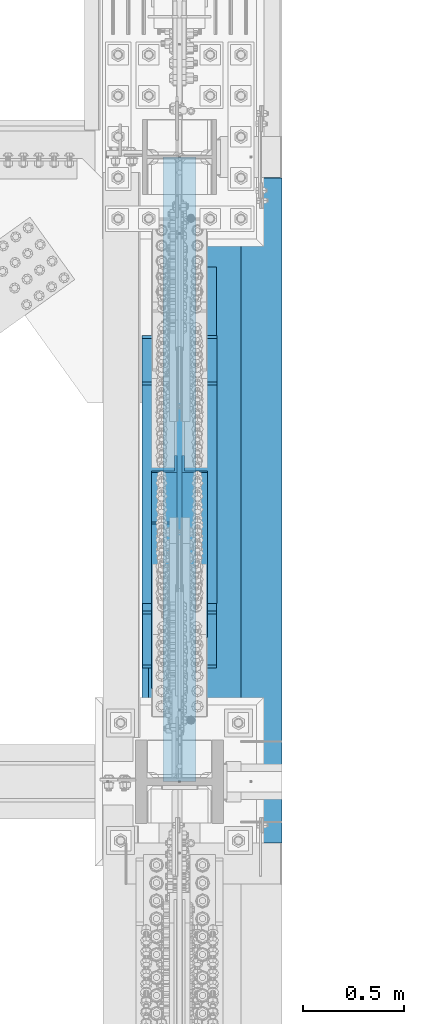
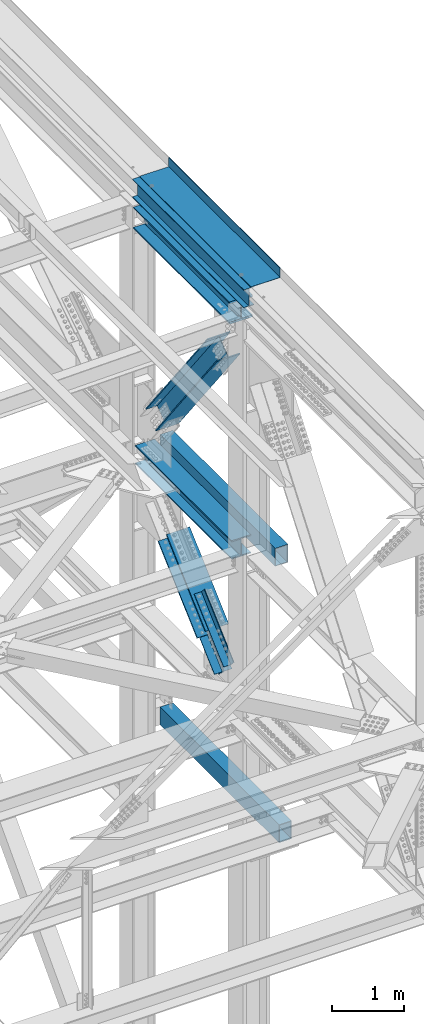
# One storey, part 1991 of 3843: 6 beams, 5 members, 7 elements without a shape of their own.
"""IFC2X3 building model written with IfcOpenShell, lengths in millimetres."""

import ifcopenshell
import ifcopenshell.guid

model = None  # the IFC model being written
_history = None  # IfcOwnerHistory: only IFC2X3 demands one
_inside = {}  # id of a spatial element -> (the spatial element, [elements in it])
_under = {}  # id of a project, library or spatial element -> (it, [spatial elements below it])
_declared = {}  # id of a project -> (the project, [libraries it declares])
_typed = {}  # id of a type object -> (the type object, [elements of that type])
_made_of = {}  # id of a material, layer set ... -> (it, [elements and type objects made of it])


def new_model(schema):
    """Start an empty IFC model of exactly this schema.

    Asked for "IFC4X3", IfcOpenShell would pick the latest addendum, in which some entities
    have other attributes; the version numbers below select the first issue.
    IFC2X3 requires an IfcOwnerHistory on every rooted entity: one is made here for all.
    """
    global model, _history
    if schema == "IFC4X3":
        model = ifcopenshell.file(schema_version=(4, 3, 0, 0))
    else:
        model = ifcopenshell.file(schema=schema)
    _inside.clear()
    _under.clear()
    _declared.clear()
    _typed.clear()
    _made_of.clear()
    _history = None
    if model.schema == "IFC2X3":
        org = make("IfcOrganization", Name="unknown")
        user = make(
            "IfcPersonAndOrganization",
            ThePerson=make("IfcPerson", FamilyName="unknown"),
            TheOrganization=org,
        )
        app = make(
            "IfcApplication",
            ApplicationDeveloper=org,
            Version="unknown",
            ApplicationFullName="unknown",
            ApplicationIdentifier="unknown",
        )
        _history = make(
            "IfcOwnerHistory",
            OwningUser=user,
            OwningApplication=app,
            ChangeAction="ADDED",
            CreationDate=0,
        )
    return model


def make(cls, **values):
    """One entity of the class cls with the attributes given. An attribute that is None is left unset."""
    return model.create_entity(
        cls, **{name: value for name, value in values.items() if value is not None}
    )


def rooted(cls, **values):
    """An entity with a GlobalId (a new one), such as an element, a storey or a relation."""
    return make(cls, GlobalId=ifcopenshell.guid.new(), OwnerHistory=_history, **values)


def si_unit(unit_type, name, prefix=None):
    """IfcSIUnit, for example si_unit("LENGTHUNIT", "METRE", prefix="MILLI")."""
    return make("IfcSIUnit", UnitType=unit_type, Prefix=prefix, Name=name)


def assignment(units):
    """IfcUnitAssignment: the units of a project."""
    return None if units is None else make("IfcUnitAssignment", Units=units)


def point(xyz):
    """IfcCartesianPoint."""
    return None if xyz is None else make("IfcCartesianPoint", Coordinates=xyz)


def direction(xyz):
    """IfcDirection."""
    return None if xyz is None else make("IfcDirection", DirectionRatios=xyz)


def frame(location, z_axis=None, x_axis=None):
    """IfcAxis2Placement3D, a coordinate frame: its origin and axes. An axis left out is left unset."""
    return make(
        "IfcAxis2Placement3D",
        Location=point(location),
        Axis=direction(z_axis),
        RefDirection=direction(x_axis),
    )


def origin_with_axes():
    """The frame at (0, 0, 0) with the z axis (0, 0, 1) and the x axis (1, 0, 0) written out."""
    return frame((0.0, 0.0, 0.0), z_axis=(0.0, 0.0, 1.0), x_axis=(1.0, 0.0, 0.0))


def place(relative_to, where):
    """IfcLocalPlacement: puts the frame where relative to a parent placement (None: the world)."""
    return make(
        "IfcLocalPlacement", PlacementRelTo=relative_to, RelativePlacement=where
    )


def context(
    kind, dimensions, precision=None, world=None, true_north=None, identifier=None
):
    """IfcGeometricRepresentationContext, for example the 3D "Model" context."""
    return make(
        "IfcGeometricRepresentationContext",
        ContextIdentifier=identifier,
        ContextType=kind,
        CoordinateSpaceDimension=dimensions,
        Precision=precision,
        WorldCoordinateSystem=world,
        TrueNorth=true_north,
    )


def subcontext(parent, identifier, kind, view, scale=None):
    """IfcGeometricRepresentationSubContext, for example "Body" below "Model"."""
    return make(
        "IfcGeometricRepresentationSubContext",
        ContextIdentifier=identifier,
        ContextType=kind,
        ParentContext=parent,
        TargetScale=scale,
        TargetView=view,
    )


def project(units=None, contexts=None):
    """IfcProject with its units and contexts."""
    return rooted(
        "IfcProject",
        Name="project",
        RepresentationContexts=contexts,
        UnitsInContext=assignment(units),
    )


def spatial(cls, under=None, at=None, **own):
    """A site, building, storey or space (cls), placed at a placement, below another one or the project."""
    s = rooted(cls, ObjectPlacement=at, **own)
    if under is not None:
        _under.setdefault(under.id(), (under, []))[1].append(s)
    return s


def faces_of(points, faces, orient=None, outer=None):
    """IfcFace entities. A face is a list of loops; a loop is a list of indices into points, from 0.

    orient and outer hold one flag for each loop. By default every Orientation is true, the
    first loop of a face is its IfcFaceOuterBound and the others are IfcFaceBound.
    """
    made = []
    for i, loops in enumerate(faces):
        bounds = []
        for j, loop in enumerate(loops):
            is_outer = j == 0 if outer is None else outer[i][j]
            bounds.append(
                make(
                    "IfcFaceOuterBound" if is_outer else "IfcFaceBound",
                    Bound=make("IfcPolyLoop", Polygon=[points[k] for k in loop]),
                    Orientation=True if orient is None else orient[i][j],
                )
            )
        made.append(make("IfcFace", Bounds=bounds))
    return made


def faceted_brep(points, faces, orient=None, outer=None, voids=None):
    """IfcFacetedBrep: a solid bounded by flat faces; with voids (closed shells), ...WithVoids."""
    shared = [point(p) for p in points]
    hull = make("IfcClosedShell", CfsFaces=faces_of(shared, faces, orient, outer))
    if voids is None:
        return make("IfcFacetedBrep", Outer=hull)
    return make(
        "IfcFacetedBrepWithVoids",
        Outer=hull,
        Voids=[
            make(cls, CfsFaces=faces_of(shared, fs, o, b)) for cls, fs, o, b in voids
        ],
    )


def shape(context_of_items, identifier, shape_type, items):
    """IfcShapeRepresentation: the items that make up one representation, for example the "Body"."""
    return make(
        "IfcShapeRepresentation",
        ContextOfItems=context_of_items,
        RepresentationIdentifier=identifier,
        RepresentationType=shape_type,
        Items=items,
    )


def material(Name=None, Category=None):
    """IfcMaterial."""
    return make("IfcMaterial", Name=Name, Category=Category)


def made_of(thing, what):
    """Note that an element or type object is made of a material, layer set ...; save() writes the relation."""
    if what is not None:
        _made_of.setdefault(what.id(), (what, []))[1].append(thing)
    return thing


def type_object(cls, material=None, **own):
    """A type object (cls), such as IfcWallType, which elements share."""
    return made_of(rooted(cls, **own), material)


def element(
    cls,
    number,
    at=None,
    inside=None,
    cuts=None,
    type_object=None,
    material=None,
    context=None,
    identifier="Body",
    shape_type=None,
    held_by="IfcProductDefinitionShape",
    body=None,
    shapes=None,
    **own,
):
    """One element of the class cls, such as IfcWall. Its Tag is "e" and its number.

    at: its placement. inside: the storey or other place that contains it. cuts: it is an
    opening in that element (IfcRelVoidsElement). A single representation is given by context,
    identifier, shape_type and body (its items); several are given by shapes. held_by: the class
    of the entity that holds the representations. save() writes the other relations.
    """
    e = rooted(cls, Tag="e%d" % number, ObjectPlacement=at, **own)
    if body is not None:
        shapes = [shape(context, identifier, shape_type, body)]
    if shapes is not None:
        e.Representation = make(held_by, Representations=shapes)
    if inside is not None:
        _inside.setdefault(inside.id(), (inside, []))[1].append(e)
    if cuts is not None:
        rooted(
            "IfcRelVoidsElement", RelatingBuildingElement=cuts, RelatedOpeningElement=e
        )
    if type_object is not None:
        _typed.setdefault(type_object.id(), (type_object, []))[1].append(e)
    return made_of(e, material)


def aggregate(whole, parts):
    """IfcRelAggregates: a whole, such as a stair, and the parts it consists of."""
    return rooted("IfcRelAggregates", RelatingObject=whole, RelatedObjects=parts)


def save(model, path):
    """Write the relations noted so far, then the file.

    IfcRelAggregates (storeys below a building ...), IfcRelContainedInSpatialStructure (elements
    in a storey), IfcRelDefinesByType, IfcRelAssociatesMaterial and IfcRelDeclares: one each for
    every whole, place, type object, material and project.
    """
    for whole, parts in _under.values():
        aggregate(whole, parts)
    for where, things in _inside.values():
        rooted(
            "IfcRelContainedInSpatialStructure",
            RelatedElements=things,
            RelatingStructure=where,
        )
    for kind, things in _typed.values():
        rooted("IfcRelDefinesByType", RelatedObjects=things, RelatingType=kind)
    for what, things in _made_of.values():
        rooted("IfcRelAssociatesMaterial", RelatedObjects=things, RelatingMaterial=what)
    for by, libraries in _declared.values():
        rooted("IfcRelDeclares", RelatingContext=by, RelatedDefinitions=libraries)
    model.write(path)


model = new_model("IFC2X3")

# Units and contexts
model_context = context("Model", 3, precision=1e-05, world=origin_with_axes())
body_context = subcontext(model_context, "Body", "Model", "MODEL_VIEW")
ifc_project = project(units=[si_unit("LENGTHUNIT", "METRE", prefix="MILLI"), si_unit("AREAUNIT", "SQUARE_METRE"), si_unit("VOLUMEUNIT", "CUBIC_METRE"), si_unit("MASSUNIT", "GRAM", prefix="KILO"), si_unit("TIMEUNIT", "SECOND"), si_unit("PLANEANGLEUNIT", "RADIAN"), si_unit("SOLIDANGLEUNIT", "STERADIAN"), si_unit("THERMODYNAMICTEMPERATUREUNIT", "DEGREE_CELSIUS"), si_unit("LUMINOUSINTENSITYUNIT", "LUMEN")], contexts=[model_context])

# Site, building, storey
site_placement = place(None, origin_with_axes())
site = spatial("IfcSite", under=ifc_project, at=site_placement, CompositionType="ELEMENT")
building_placement = place(site_placement, origin_with_axes())
building = spatial("IfcBuilding", under=site, at=building_placement, Name="Undefined", CompositionType="ELEMENT")
storey_placement = place(building_placement, origin_with_axes())
storey = spatial("IfcBuildingStorey", under=building, at=storey_placement, Name="Undefined", CompositionType="ELEMENT", Elevation=0.0)

# Assembly, beam
assembly_1_placement = place(storey_placement, origin_with_axes())
assembly_1 = element("IfcElementAssembly", 1, at=assembly_1_placement, inside=storey, Name="BEAM", AssemblyPlace="NOTDEFINED", PredefinedType="RIGID_FRAME")
ifc_material_1 = material(Name="STEEL/A992")
beam_type_1 = type_object("IfcBeamType", Name="W12X26", PredefinedType="NOTDEFINED")
beam_1_placement = place(assembly_1_placement, frame((85648.8000000031, 89115.9, 46612.1750000001), z_axis=(0.0, 0.0, 1.0), x_axis=(0.0, 1.0, 0.0)))
beam_1 = element("IfcBeam", 2, at=beam_1_placement, type_object=beam_type_1, material=ifc_material_1, Name="BEAM", ObjectType="W12X26", context=body_context, shape_type="Brep", body=[
    faceted_brep([(0.0, 82.5500000000029, -155.574999999997), (0.0, 82.5500000000029, -146.050000000003), (3098.79999999999, 82.5500000000029, -146.050000000003), (3098.79999999999, 82.5500000000029, -155.574999999997), (0.0, 3.17500000000291, -146.050000000003), (3098.79999999999, 3.17500000000291, -146.050000000003), (0.0, 3.17500000000291, 146.050000000003), (3098.79999999999, 3.17500000000291, 146.050000000003), (0.0, 82.5500000000029, 146.050000000003), (3098.79999999999, 82.5500000000029, 146.050000000003), (0.0, 82.5500000000029, 155.574999999997), (3098.79999999999, 82.5500000000029, 155.574999999997), (0.0, -82.5500000000029, 155.574999999997), (3098.79999999999, -82.5500000000029, 155.574999999997), (0.0, -82.5500000000029, 146.050000000003), (3098.79999999999, -82.5500000000029, 146.050000000003), (0.0, -3.17500000000291, 146.050000000003), (3098.79999999999, -3.17500000000291, 146.050000000003), (0.0, -3.17500000000291, -146.050000000003), (3098.79999999999, -3.17500000000291, -146.050000000003), (0.0, -82.5500000000029, -146.050000000003), (3098.79999999999, -82.5500000000029, -146.050000000003), (0.0, -82.5500000000029, -155.574999999997), (3098.79999999999, -82.5500000000029, -155.574999999997)], [[[0, 1, 2, 3]], [[1, 4, 5, 2]], [[4, 6, 7, 5]], [[6, 8, 9, 7]], [[8, 10, 11, 9]], [[10, 12, 13, 11]], [[12, 14, 15, 13]], [[14, 16, 17, 15]], [[16, 18, 19, 17]], [[18, 20, 21, 19]], [[20, 22, 23, 21]], [[22, 0, 3, 23]], [[5, 7, 9, 11, 13, 15, 17, 19, 21, 23, 3, 2]], [[22, 20, 18, 16, 14, 12, 10, 8, 6, 4, 1, 0]]]),
])

assembly_2_placement = place(storey_placement, origin_with_axes())
assembly_2 = element("IfcElementAssembly", 3, at=assembly_2_placement, inside=storey, Name="GIRT", AssemblyPlace="NOTDEFINED", PredefinedType="RIGID_FRAME")
ifc_material_2 = material()
beam_type_2 = type_object("IfcBeamType", Name="HSS12X8X3/8", PredefinedType="NOTDEFINED")
beam_2_placement = place(assembly_2_placement, frame((86055.2, 88912.7, 42214.8), z_axis=(0.0, 0.0, 1.0), x_axis=(0.0, 1.0, 0.0)))
beam_2 = element("IfcBeam", 4, at=beam_2_placement, type_object=beam_type_2, material=ifc_material_2, Name="GIRT", ObjectType="HSS12X8X3/8", context=body_context, shape_type="Brep", body=[
    faceted_brep([(6.35000000002037, -101.600000000006, -152.400000000001), (6.35000000002037, 101.600000000006, -152.400000000001), (3198.81250000004, 101.600000000006, -152.400000000001), (3198.81250000004, -101.600000000006, -152.400000000001), (6.35000000002037, -101.600000000006, 152.400000000001), (3198.81250000004, -101.600000000006, 152.400000000001), (6.35000000002037, 101.600000000006, 152.400000000001), (3198.81250000004, 101.600000000006, 152.400000000001), (6.35000000002037, 92.0749999999971, 142.875), (6.35000000002037, -92.0749999999971, 142.875), (6.35000000002037, -92.0749999999971, -142.875), (6.35000000002037, 92.0749999999971, -142.875), (3198.81250000004, -92.0749999999971, 142.875), (3198.81250000004, -92.0749999999971, -142.875), (3198.81250000004, 92.0749999999971, -142.875), (3198.81250000004, 92.0749999999971, 142.875)], [[[0, 1, 2, 3]], [[4, 0, 3, 5]], [[6, 4, 5, 7]], [[1, 6, 7, 2]], [[0, 4, 6, 1], [8, 9, 10, 11]], [[10, 9, 12, 13]], [[11, 10, 13, 14]], [[8, 11, 14, 15]], [[9, 8, 15, 12]], [[2, 7, 5, 3], [14, 13, 12, 15]]]),
])
aggregate(assembly_2, [beam_2])

assembly_3_placement = place(storey_placement, origin_with_axes())
assembly_3 = element("IfcElementAssembly", 5, at=assembly_3_placement, inside=storey, Name="GIRT", AssemblyPlace="NOTDEFINED", PredefinedType="RIGID_FRAME")
beam_3_placement = place(assembly_3_placement, frame((86055.2, 88812.6870000123, 37592.0), z_axis=(0.0, 0.0, 1.0), x_axis=(0.0, 1.0, 0.0)))
beam_3 = element("IfcBeam", 6, at=beam_3_placement, type_object=beam_type_2, material=ifc_material_2, Name="GIRT", ObjectType="HSS12X8X3/8", context=body_context, shape_type="Brep", body=[
    faceted_brep([(0.0, 92.0749999999971, -142.875), (0.0, -92.0749999999971, -142.875), (3298.82599997523, -92.0749999999971, -142.875), (3298.82599997523, 92.0749999999971, -142.875), (0.0, -92.0749999999971, 142.875), (3298.82599997523, -92.0749999999971, 142.875), (0.0, 92.0749999999971, 142.875), (3298.82599997523, 92.0749999999971, 142.875), (0.0, 101.600000000006, -152.400000000001), (0.0, 101.600000000006, 152.400000000001), (3298.82599997523, 101.600000000006, 152.400000000001), (3298.82599997523, 101.600000000006, -152.400000000001), (0.0, -101.600000000006, 152.400000000001), (3298.82599997523, -101.600000000006, 152.400000000001), (0.0, -101.600000000006, -152.400000000001), (3298.82599997523, -101.600000000006, -152.400000000001)], [[[0, 1, 2, 3]], [[1, 4, 5, 2]], [[4, 6, 7, 5]], [[6, 0, 3, 7]], [[8, 9, 10, 11]], [[9, 12, 13, 10]], [[12, 14, 15, 13]], [[14, 8, 11, 15]], [[13, 15, 11, 10], [5, 7, 3, 2]], [[14, 12, 9, 8], [6, 4, 1, 0]]]),
])
aggregate(assembly_3, [beam_3])

assembly_4_placement = place(storey_placement, origin_with_axes())
assembly_4 = element("IfcElementAssembly", 7, at=assembly_4_placement, inside=storey, Name="BEAM", AssemblyPlace="NOTDEFINED", PredefinedType="RIGID_FRAME")
beam_type_3 = type_object("IfcBeamType", Name="W14X120", PredefinedType="NOTDEFINED")
beam_4_placement = place(assembly_4_placement, frame((85648.7999996898, 89115.9000000775, 46272.45), z_axis=(0.0, 0.0, 1.0), x_axis=(0.0, 1.0, 0.0)))
beam_4 = element("IfcBeam", 8, at=beam_4_placement, type_object=beam_type_3, material=ifc_material_1, Name="BEAM", ObjectType="W14X120", context=body_context, shape_type="Brep", body=[
    faceted_brep([(229.648571506506, -185.737500000003, 184.150000000001), (229.648571506506, 185.737500000003, 184.150000000001), (215.89999999998, 185.737500000003, 160.337500000001), (215.89999999998, 7.14375000000291, 160.337500000001), (215.89999999998, -7.14375000000291, 160.337500000001), (215.89999999998, -185.737500000003, 160.337500000001), (2903.53749999998, -185.737500000003, -184.150000000001), (2889.78891587461, -185.737500000003, -160.337500000001), (229.648584125331, -185.737500000003, -160.337500000001), (215.89999999998, -185.737500000003, -184.150000000001), (2903.53749999998, 185.737500000003, -184.150000000001), (215.89999999998, 185.737500000003, -184.150000000001), (2889.78891587461, 185.737500000003, -160.337500000001), (229.648584125331, 185.737500000003, -160.337500000001), (2889.78891587461, 7.14375000000291, -160.337500000001), (229.648584125331, 7.14375000000291, -160.337500000001), (2889.55970728036, 7.14375000000291, -159.940499496464), (2889.55970728036, -7.14375000000291, -159.940499496464), (2889.78891587461, -7.14375000000291, -160.337500000001), (2882.98050683591, 7.14375000000291, -159.940499496464), (2882.98050683591, -7.14375000000291, -159.940499496464), (2829.67387659333, 7.14375000000291, -150.671698168706), (2829.67387659333, -7.14375000000291, -150.671698168706), (2824.70199420204, 7.14375000000291, -148.151780799373), (2824.70199420204, -7.14375000000291, -148.151780799373), (2821.99155201387, 7.14375000000291, -143.281144166889), (2821.99155201387, -7.14375000000291, -143.281144166889), (2822.47075918806, 7.14375000000291, -137.72777054851), (2822.47075918806, -7.14375000000291, -137.72777054851), (2825.97550800437, 7.14375000000291, -133.39345009478), (2825.97550800437, -7.14375000000291, -133.39345009478), (2831.30557365589, 7.14375000000291, -131.762500000004), (2831.30557365589, -7.14375000000291, -131.762500000004), (2900.36249999997, 7.14375000000291, -131.762500000004), (2900.36249999997, -7.14375000000291, -131.762500000004), (2900.36249999997, -7.14375000000291, 131.762500000004), (2900.36249999997, 7.14375000000291, 131.762500000004), (2826.46256780367, 7.14375000000291, 131.762500000004), (2826.46256780367, -7.14375000000291, 131.762500000004), (2821.13250216469, 7.14375000000291, 133.393450086303), (2821.13250216469, -7.14375000000291, 133.393450086303), (2817.62775334714, 7.14375000000291, 137.727770520425), (2817.62775334714, -7.14375000000291, 137.727770520425), (2817.14854615215, 7.14375000000291, 143.281144122484), (2817.14854615215, -7.14375000000291, 143.281144122484), (2819.85898830618, 7.14375000000291, 148.151780757398), (2819.85898830618, -7.14375000000291, 148.151780757398), (2824.83087066654, 7.14375000000291, 150.67169815574), (2824.83087066654, -7.14375000000291, 150.67169815574), (2878.1374984741, 7.14375000000291, 159.940499496464), (2878.1374984741, -7.14375000000291, 159.940499496464), (2903.53749999998, 7.14375000000291, 159.940499496464), (2903.53749999998, -7.14375000000291, 159.940499496464), (2903.53749999998, 7.14375000000291, 160.337500000001), (2903.53749999998, -7.14375000000291, 160.337500000001), (2903.53749999998, -185.737500000003, 160.337500000001), (2903.53749999998, 185.737500000003, 160.337500000001), (2889.78892849344, 185.737500000003, 184.150000000001), (2889.78892849344, -185.737500000003, 184.150000000001), (215.89999999998, 7.14375000000291, 159.940499496464), (215.89999999998, -7.14375000000291, 159.940499496464), (241.300001525844, 7.14375000000291, 159.940499496464), (241.300001525844, -7.14375000000291, 159.940499496464), (294.606629333401, 7.14375000000291, 150.67169815574), (294.606629333401, -7.14375000000291, 150.67169815574), (299.578511693762, 7.14375000000291, 148.151780757398), (299.578511693762, -7.14375000000291, 148.151780757398), (302.28895384779, 7.14375000000291, 143.281144122484), (302.28895384779, -7.14375000000291, 143.281144122484), (301.809746652798, 7.14375000000291, 137.727770520425), (301.809746652798, -7.14375000000291, 137.727770520425), (298.30499783525, 7.14375000000291, 133.393450086303), (298.30499783525, -7.14375000000291, 133.393450086303), (292.974932196274, 7.14375000000291, 131.762500000004), (292.974932196274, -7.14375000000291, 131.762500000004), (219.074999999968, 7.14375000000291, 131.762500000004), (219.074999999968, -7.14375000000291, 131.762500000004), (219.074999999968, 7.14375000000291, -131.762500000004), (219.074999999968, -7.14375000000291, -131.762500000004), (288.131926344053, 7.14375000000291, -131.762500000004), (288.131926344053, -7.14375000000291, -131.762500000004), (293.461991995573, 7.14375000000291, -133.39345009478), (293.461991995573, -7.14375000000291, -133.39345009478), (296.966740811884, 7.14375000000291, -137.72777054851), (296.966740811884, -7.14375000000291, -137.72777054851), (297.445947986067, 7.14375000000291, -143.281144166889), (297.445947986067, -7.14375000000291, -143.281144166889), (294.7355057979, 7.14375000000291, -148.151780799373), (294.7355057979, -7.14375000000291, -148.151780799373), (289.763623406616, 7.14375000000291, -150.671698168706), (289.763623406616, -7.14375000000291, -150.671698168706), (236.456993164029, 7.14375000000291, -159.940499496464), (236.456993164029, -7.14375000000291, -159.940499496464), (229.877792719577, 7.14375000000291, -159.940499496464), (229.877792719577, -7.14375000000291, -159.940499496464), (229.648584125331, -7.14375000000291, -160.337500000001)], [[[0, 1, 2, 3, 4, 5]], [[6, 7, 8, 9]], [[10, 6, 9, 11]], [[12, 10, 11, 13]], [[14, 12, 13, 15]], [[6, 10, 12, 14, 16, 17, 18, 7]], [[19, 20, 17, 16]], [[20, 19, 21, 22]], [[22, 21, 23, 24]], [[24, 23, 25, 26]], [[26, 25, 27, 28]], [[28, 27, 29, 30]], [[30, 29, 31, 32]], [[32, 31, 33, 34]], [[35, 34, 33, 36]], [[37, 38, 35, 36]], [[38, 37, 39, 40]], [[40, 39, 41, 42]], [[42, 41, 43, 44]], [[44, 43, 45, 46]], [[46, 45, 47, 48]], [[48, 47, 49, 50]], [[50, 49, 51, 52]], [[52, 51, 53, 54]], [[55, 54, 53, 56, 57, 58]], [[55, 58, 0, 5]], [[54, 55, 5, 4]], [[59, 60, 4, 3]], [[61, 62, 60, 59]], [[62, 61, 63, 64]], [[64, 63, 65, 66]], [[66, 65, 67, 68]], [[68, 67, 69, 70]], [[70, 69, 71, 72]], [[72, 71, 73, 74]], [[74, 73, 75, 76]], [[76, 75, 77, 78]], [[79, 80, 78, 77]], [[80, 79, 81, 82]], [[82, 81, 83, 84]], [[84, 83, 85, 86]], [[86, 85, 87, 88]], [[88, 87, 89, 90]], [[90, 89, 91, 92]], [[92, 91, 93, 94]], [[18, 17, 20, 22, 24, 26, 28, 30, 32, 34, 35, 38, 40, 42, 44, 46, 48, 50, 52, 54, 4, 60, 62, 64, 66, 68, 70, 72, 74, 76, 78, 80, 82, 84, 86, 88, 90, 92, 94, 95]], [[7, 18, 95, 8]], [[94, 93, 15, 13, 11, 9, 8, 95]], [[91, 89, 87, 85, 83, 81, 79, 77, 75, 73, 71, 69, 67, 65, 63, 61, 59, 3, 53, 51, 49, 47, 45, 43, 41, 39, 37, 36, 33, 31, 29, 27, 25, 23, 21, 19, 16, 14, 15, 93]], [[56, 53, 3, 2]], [[57, 56, 2, 1]], [[58, 57, 1, 0]]]),
])
aggregate(assembly_4, [beam_4])

assembly_5_placement = place(storey_placement, origin_with_axes())
assembly_5 = element("IfcElementAssembly", 9, at=assembly_5_placement, inside=storey, Name="BEAM", AssemblyPlace="NOTDEFINED", PredefinedType="RIGID_FRAME")
beam_type_4 = type_object("IfcBeamType", Name="W12X87", PredefinedType="NOTDEFINED")
beam_5_placement = place(assembly_5_placement, frame((85648.8, 89115.9, 42246.55), z_axis=(0.0, 0.0, 1.0), x_axis=(0.0, 1.0, 0.0)))
beam_5 = element("IfcBeam", 10, at=beam_5_placement, type_object=beam_type_4, material=ifc_material_1, Name="BEAM", ObjectType="W12X87", context=body_context, shape_type="Brep", body=[
    faceted_brep([(2903.53749999999, -153.987500000003, 138.112500000003), (2903.53749999999, -6.35000000000582, 138.112500000003), (2903.53749999999, 6.35000000000582, 138.112500000003), (2903.53749999999, 153.987500000003, 138.112500000003), (2891.6228988839, 153.987500000003, 158.75), (2891.6228988839, -153.987500000003, 158.75), (219.074999999139, 147.637500000012, -158.75), (219.074999999139, -147.637499999983, -158.75), (219.074999999139, -153.987500000003, -158.75), (219.074999999139, -153.987500000003, -138.112500000003), (219.074999999139, -147.637499999983, -138.112500000003), (219.074999999139, -6.35000000000582, -138.112500000003), (219.074999999139, -6.35000000000582, 138.112500000003), (219.074999999139, -147.637499999983, 138.112500000003), (219.074999999139, -153.987500000003, 138.112500000003), (219.074999999139, -153.987500000003, 158.75), (219.074999999139, -147.637499999983, 158.75), (219.074999999139, 147.637500000012, 158.75), (219.074999999139, 153.987500000003, 158.75), (219.074999999139, 153.987500000003, 138.112500000003), (219.074999999139, 147.637500000012, 138.112500000003), (219.074999999139, 6.35000000000582, 138.112500000003), (219.074999999139, 6.35000000000582, 115.040000000001), (219.074999999139, 6.35000000000582, -115.040000000001), (219.074999999139, 6.35000000000582, -138.112500000003), (219.074999999139, 147.637500000012, -138.112500000003), (219.074999999139, 153.987500000003, -138.112500000003), (219.074999999139, 153.987500000003, -158.75), (2903.53749999999, -6.35000000000582, 137.715499999998), (2903.53749999999, 6.35000000000582, 137.715499999998), (2878.1375, -6.35000000000582, 137.715499999998), (2878.1375, 6.35000000000582, 137.715499999998), (2828.63614027292, -6.35000000000582, 131.692772740622), (2828.63614027292, 6.35000000000582, 131.692772740622), (2823.46891840544, -6.35000000000582, 129.36583947148), (2823.46891840544, 6.35000000000582, 129.36583947148), (2820.53799184038, -6.35000000000582, 124.515636410055), (2820.53799184038, 6.35000000000582, 124.515636410055), (2820.88084176094, -6.35000000000582, 118.859024862606), (2820.88084176094, 6.35000000000582, 118.859024862606), (2824.37610711175, -6.35000000000582, 114.398316354491), (2824.37610711175, 6.35000000000582, 114.398316354491), (2829.7865436455, -6.35000000000582, 112.712500000001), (2829.7865436455, 6.35000000000582, 112.712500000001), (2900.36249999999, -6.35000000000582, 112.712500000001), (2900.36249999999, 6.35000000000582, 112.712500000001), (2900.36249999999, -6.35000000000582, -112.712500000001), (2900.36249999999, 6.35000000000582, -112.712500000001), (2836.4635436455, -6.35000000000582, -112.712500000001), (2836.4635436455, 6.35000000000582, -112.712500000001), (2831.05310711174, -6.35000000000582, -114.398316354491), (2831.05310711174, 6.35000000000582, -114.398316354491), (2827.55784176094, -6.35000000000582, -118.859024862599), (2827.55784176094, 6.35000000000582, -118.859024862599), (2827.21499184037, -6.35000000000582, -124.515636410055), (2827.21499184037, 6.35000000000582, -124.515636410055), (2830.14591840543, -6.35000000000582, -129.36583947148), (2830.14591840543, 6.35000000000582, -129.36583947148), (2835.31314027292, -6.35000000000582, -131.692772740622), (2835.31314027292, 6.35000000000582, -131.692772740622), (2884.81449999999, -6.35000000000582, -137.715499999998), (2884.81449999999, 6.35000000000582, -137.715499999998), (2891.39369200917, -6.35000000000582, -137.715499999998), (2891.39369200917, 6.35000000000582, -137.715499999998), (2891.62288401835, 6.35000000000582, -138.112500000003), (2891.62288401835, 153.987500000003, -138.112500000003), (2903.53749999999, 153.987500000003, -158.75), (2903.53749999999, -153.987500000003, -158.75), (2891.62288401835, -153.987500000003, -138.112500000003), (2891.62288401835, -6.35000000000582, -138.112500000003)], [[[0, 1, 2, 3, 4, 5]], [[6, 7, 8, 9, 10, 11, 12, 13, 14, 15, 16, 17, 18, 19, 20, 21, 22, 23, 24, 25, 26, 27]], [[15, 14, 0, 5]], [[18, 17, 16, 15, 5, 4]], [[19, 18, 4, 3]], [[21, 20, 19, 3, 2]], [[28, 29, 2, 1]], [[30, 31, 29, 28]], [[32, 33, 31, 30]], [[34, 35, 33, 32]], [[36, 37, 35, 34]], [[38, 39, 37, 36]], [[40, 41, 39, 38]], [[42, 43, 41, 40]], [[43, 42, 44, 45]], [[44, 46, 47, 45]], [[48, 49, 47, 46]], [[50, 51, 49, 48]], [[52, 53, 51, 50]], [[54, 55, 53, 52]], [[56, 57, 55, 54]], [[58, 59, 57, 56]], [[60, 61, 59, 58]], [[61, 60, 62, 63]], [[24, 23, 22, 21, 2, 29, 31, 33, 35, 37, 39, 41, 43, 45, 47, 49, 51, 53, 55, 57, 59, 61, 63, 64]], [[26, 25, 24, 64, 65]], [[27, 26, 65, 66]], [[8, 7, 6, 27, 66, 67]], [[9, 8, 67, 68]], [[11, 10, 9, 68, 69]], [[67, 66, 65, 64, 63, 62, 69, 68]], [[60, 58, 56, 54, 52, 50, 48, 46, 44, 42, 40, 38, 36, 34, 32, 30, 28, 1, 12, 11, 69, 62]], [[14, 13, 12, 1, 0]]]),
])
aggregate(assembly_5, [beam_5])

# Assembly, members
assembly_6_placement = place(storey_placement, origin_with_axes())
assembly_6 = element("IfcElementAssembly", 11, at=assembly_6_placement, inside=storey, AssemblyPlace="NOTDEFINED", PredefinedType="RIGID_FRAME")
ifc_material_3 = material(Name="STEEL/A572-50")
member_type_1 = type_object("IfcMemberType", Name="L5X5X1/2", PredefinedType="NOTDEFINED")
member_1_placement = place(assembly_6_placement, frame((85725.0000002308, 90692.3988300413, 40528.8383040495), z_axis=(0.0, 0.672974507774426, -0.739665675752072), x_axis=(0.0, -0.739665675752075, -0.672974507774422)))
member_1 = element("IfcMember", 12, at=member_1_placement, type_object=member_type_1, material=ifc_material_3, Name="ANGLE", ObjectType="L5X5X1/2", context=body_context, shape_type="Brep", body=[
    faceted_brep([(-1.01863406598568e-10, 63.5, -63.5000000002037), (1.01863406598568e-10, 63.5, 63.5000000002074), (1104.90000001364, 63.5, 63.500000003929), (1104.90000001345, 63.5, -63.499999996493), (1.01863406598568e-10, 50.8000000000029, 63.5000000002074), (1104.90000001364, 50.8000000000029, 63.500000003929), (0.0, 50.8000000000029, -50.8000000000029), (1104.90000001348, 50.8000000000029, -50.7999999964522), (-7.27595761418343e-11, -63.5, -50.8000000001666), (1104.90000001348, -63.5, -50.7999999964522), (-1.01863406598568e-10, -63.5, -63.5000000002037), (1104.90000001345, -63.5, -63.499999996493)], [[[0, 1, 2, 3]], [[1, 4, 5, 2]], [[4, 6, 7, 5]], [[6, 8, 9, 7]], [[8, 10, 11, 9]], [[10, 0, 3, 11]], [[5, 7, 9, 11, 3, 2]], [[10, 8, 6, 4, 1, 0]]]),
])
member_2_placement = place(assembly_6_placement, frame((85572.6000002308, 90361.2112504054, 40892.8462747237), z_axis=(0.0, -0.672974507774418, 0.739665675752079), x_axis=(0.0, -0.739665675752075, -0.672974507774422)))
member_2 = element("IfcMember", 13, at=member_2_placement, type_object=member_type_1, material=ifc_material_3, Name="ANGLE", ObjectType="L5X5X1/2", context=body_context, shape_type="Brep", body=[
    faceted_brep([(-1.01863406598568e-10, 63.5, -63.5000000002037), (1.01863406598568e-10, 63.5, 63.5000000002074), (1104.90000001364, 63.5, 63.500000003929), (1104.90000001345, 63.5, -63.499999996493), (1.01863406598568e-10, 50.8000000000029, 63.5000000002074), (1104.90000001364, 50.8000000000029, 63.500000003929), (0.0, 50.8000000000029, -50.8000000000029), (1104.90000001348, 50.8000000000029, -50.7999999964522), (-7.27595761418343e-11, -63.5, -50.8000000001666), (1104.90000001348, -63.5, -50.7999999964522), (-1.01863406598568e-10, -63.5, -63.5000000002037), (1104.90000001345, -63.5, -63.499999996493)], [[[0, 1, 2, 3]], [[1, 4, 5, 2]], [[4, 6, 7, 5]], [[6, 8, 9, 7]], [[8, 10, 11, 9]], [[10, 0, 3, 11]], [[5, 7, 9, 11, 3, 2]], [[10, 8, 6, 4, 1, 0]]]),
])
member_3_placement = place(assembly_6_placement, frame((85572.6000002308, 89875.1422249174, 39785.2687704177), z_axis=(0.0, 0.672974507774426, -0.739665675752072), x_axis=(0.0, 0.739665675752077, 0.672974507774421)))
member_3 = element("IfcMember", 14, at=member_3_placement, type_object=member_type_1, material=ifc_material_3, Name="ANGLE", ObjectType="L5X5X1/2", context=body_context, shape_type="Brep", body=[
    faceted_brep([(-1.01863406598568e-10, 63.5, -63.5000000002037), (1.01863406598568e-10, 63.5, 63.5000000002074), (1104.90000001364, 63.5, 63.500000003929), (1104.90000001345, 63.5, -63.499999996493), (1.01863406598568e-10, 50.8000000000029, 63.5000000002074), (1104.90000001364, 50.8000000000029, 63.500000003929), (0.0, 50.8000000000029, -50.8000000000029), (1104.90000001348, 50.8000000000029, -50.7999999964522), (-7.27595761418343e-11, -63.5, -50.8000000001666), (1104.90000001348, -63.5, -50.7999999964522), (-1.01863406598568e-10, -63.5, -63.5000000002037), (1104.90000001345, -63.5, -63.499999996493)], [[[0, 1, 2, 3]], [[1, 4, 5, 2]], [[4, 6, 7, 5]], [[6, 8, 9, 7]], [[8, 10, 11, 9]], [[10, 0, 3, 11]], [[5, 7, 9, 11, 3, 2]], [[10, 8, 6, 4, 1, 0]]]),
])

# Beam
ifc_material_4 = material(Name="STEEL/A36")
beam_type_5 = type_object("IfcBeamType", PredefinedType="NOTDEFINED")
beam_6_placement = place(assembly_1_placement, frame((85680.550000003, 90665.3, 46772.5125000001), z_axis=(0.0, -1.0, 0.0), x_axis=(1.0, 0.0, 0.0)))
beam_6 = element("IfcBeam", 15, at=beam_6_placement, type_object=beam_type_5, material=ifc_material_4, Name="BENT_PLATE", context=body_context, shape_type="Brep", body=[
    faceted_brep([(466.724999999962, 4.76249999999709, -1546.22500004765), (469.899999952409, 1.58750004765898, -1549.4), (0.0, 1.58750004765898, -1549.4), (0.0, 4.76249999999709, -1546.22500004766), (466.724999999977, 160.337500000023, -1546.22500004765), (469.899999952424, 160.337500000023, -1549.4), (0.0, 4.76249999999709, 1549.4), (466.724999999962, 4.76249999999709, 1549.4), (0.0, -4.76249999999709, -1549.4), (0.0, -4.76249999999709, 1549.4), (476.249999999956, -4.76249999999709, -1549.4), (476.249999999956, -4.76249999999709, 1549.4), (466.724999999977, 160.337500000023, 1549.4), (476.249999999971, 160.337500000023, 1549.4), (476.249999999971, 160.337500000023, -1549.4)], [[[0, 1, 2, 3]], [[4, 5, 1, 0]], [[6, 7, 0, 3]], [[8, 9, 6, 3, 2]], [[9, 8, 10, 11]], [[7, 12, 4, 0]], [[7, 6, 9, 11, 13, 12]], [[11, 10, 14, 13]], [[5, 14, 10, 8, 2, 1]], [[12, 13, 14, 5, 4]]]),
])

aggregate(assembly_1, [beam_6, beam_1])

# Member
member_type_2 = type_object("IfcMemberType", Name="W14X109", PredefinedType="NOTDEFINED")
member_4_placement = place(assembly_6_placement, frame((85648.8000002308, 89115.9000004197, 39427.15), z_axis=(0.0, -0.672974507774418, 0.739665675752079), x_axis=(0.0, 0.739665675752077, 0.672974507774421)))
member_4 = element("IfcMember", 16, at=member_4_placement, type_object=member_type_2, material=ifc_material_1, ObjectType="W14X109", context=body_context, shape_type="Brep", body=[
    faceted_brep([(1361.39021627374, 185.737500000003, -182.562499996013), (1361.39021627385, 185.737500000003, -160.337499995934), (2828.07010860567, 185.737500000003, -160.337499991005), (2828.07010860555, 185.737500000003, -182.562499991072), (1361.39021627385, 6.35000000000582, -160.337499995934), (2828.07010860567, 6.35000000000582, -160.337499991005), (1361.39021627542, 6.35000000000582, 160.337500005113), (2828.07010860722, 6.35000000000582, 160.337500010046), (1361.39021627542, 185.737500000003, 160.337500005113), (2828.07010860722, 185.737500000003, 160.337500010046), (1361.39021627553, 185.737500000003, 182.562500005191), (2828.07010860734, 185.737500000003, 182.562500010121), (1361.39021627553, -185.737500000003, 182.562500005191), (2828.07010860734, -185.737500000003, 182.562500010121), (1361.39021627542, -185.737500000003, 160.337500005113), (2828.07010860722, -185.737500000003, 160.337500010046), (1361.39021627542, -6.35000000000582, 160.337500005113), (2828.07010860722, -6.35000000000582, 160.337500010046), (1361.39021627385, -6.35000000000582, -160.337499995934), (2828.07010860567, -6.35000000000582, -160.337499991005), (1361.39021627385, -185.737500000003, -160.337499995934), (2828.07010860567, -185.737500000003, -160.337499991005), (1361.39021627374, -185.737500000003, -182.562499996013), (2828.07010860555, -185.737500000003, -182.562499991072)], [[[0, 1, 2, 3]], [[1, 4, 5, 2]], [[4, 6, 7, 5]], [[6, 8, 9, 7]], [[8, 10, 11, 9]], [[10, 12, 13, 11]], [[12, 14, 15, 13]], [[14, 16, 17, 15]], [[16, 18, 19, 17]], [[18, 20, 21, 19]], [[20, 22, 23, 21]], [[22, 0, 3, 23]], [[5, 7, 9, 11, 13, 15, 17, 19, 21, 23, 3, 2]], [[22, 20, 18, 16, 14, 12, 10, 8, 6, 4, 1, 0]]]),
])

aggregate(assembly_6, [member_1, member_2, member_3, member_4])

# Assembly, member
assembly_7_placement = place(storey_placement, origin_with_axes())
assembly_7 = element("IfcElementAssembly", 17, at=assembly_7_placement, inside=storey, AssemblyPlace="NOTDEFINED", PredefinedType="RIGID_FRAME")
member_type_3 = type_object("IfcMemberType", Name="W14X90", PredefinedType="NOTDEFINED")
member_5_placement = place(assembly_7_placement, frame((85648.7999996898, 89115.9000000775, 46272.45), z_axis=(0.0, 0.792438093282068, 0.609952349217117), x_axis=(0.0, 0.6099523492171, -0.792438093282081)))
member_5 = element("IfcMember", 18, at=member_5_placement, type_object=member_type_3, material=ifc_material_1, ObjectType="W14X90", context=body_context, shape_type="Brep", body=[
    faceted_brep([(1156.18826694682, 184.149999999994, -177.800000000891), (1156.18826694681, 184.149999999994, -160.337500000896), (3956.26156898669, 184.149999999994, -160.337500003501), (3956.26156898669, 184.149999999994, -177.800000003481), (1156.18826694681, 5.55624999999418, -160.337500000896), (3956.26156898669, 5.55624999999418, -160.337500003501), (1156.18826694681, 5.55624999999418, 160.337499998757), (3956.2615689867, 5.55624999999418, 160.337499996152), (1156.18826694681, 184.149999999994, 160.337499998757), (3956.2615689867, 184.149999999994, 160.337499996152), (1156.18826694682, 184.149999999994, 177.799999998766), (3956.2615689867, 184.149999999994, 177.799999996161), (1156.18826694682, -184.149999999994, 177.799999998766), (3956.2615689867, -184.149999999994, 177.799999996161), (1156.18826694681, -184.149999999994, 160.337499998757), (3956.2615689867, -184.149999999994, 160.337499996152), (1156.18826694681, -5.55624999999418, 160.337499998757), (3956.2615689867, -5.55624999999418, 160.337499996152), (1156.18826694681, -5.55624999999418, -160.337500000896), (3956.26156898669, -5.55624999999418, -160.337500003501), (1156.18826694681, -184.149999999994, -160.337500000896), (3956.26156898669, -184.149999999994, -160.337500003501), (1156.18826694682, -184.149999999994, -177.800000000891), (3956.26156898669, -184.149999999994, -177.800000003481)], [[[0, 1, 2, 3]], [[1, 4, 5, 2]], [[4, 6, 7, 5]], [[6, 8, 9, 7]], [[8, 10, 11, 9]], [[10, 12, 13, 11]], [[12, 14, 15, 13]], [[14, 16, 17, 15]], [[16, 18, 19, 17]], [[18, 20, 21, 19]], [[20, 22, 23, 21]], [[22, 0, 3, 23]], [[5, 7, 9, 11, 13, 15, 17, 19, 21, 23, 3, 2]], [[22, 20, 18, 16, 14, 12, 10, 8, 6, 4, 1, 0]]]),
])
aggregate(assembly_7, [member_5])

save(model, "model.ifc")
